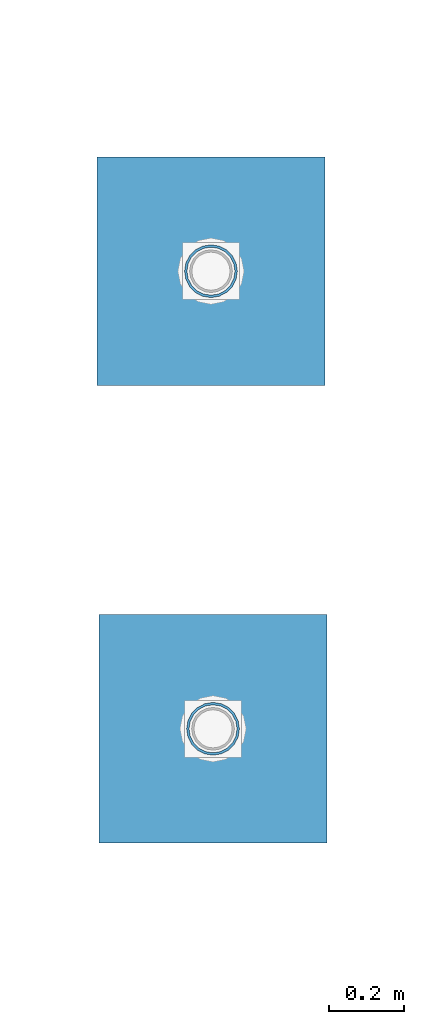
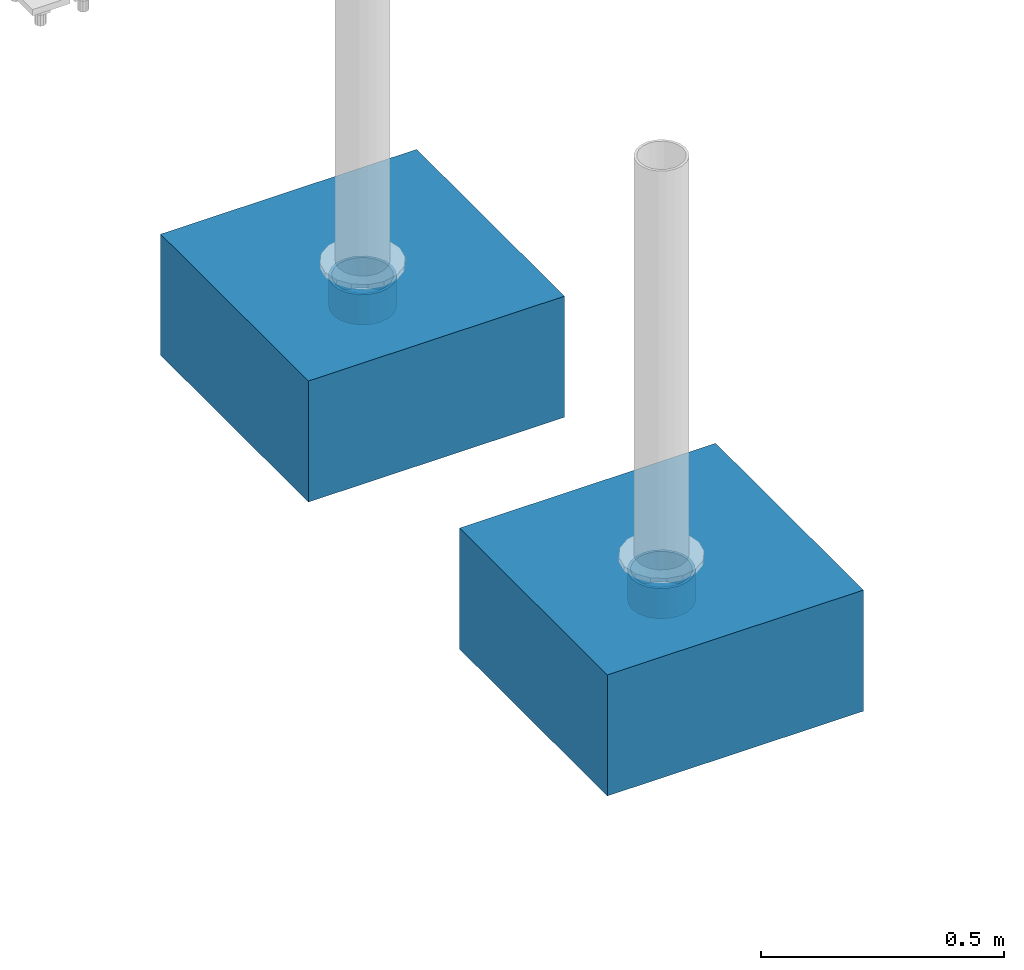
# One storey, part 1608 of 3843: 4 columns, 4 elements without a shape of their own.
"""IFC2X3 building model written with IfcOpenShell, lengths in millimetres."""

from ifc_helpers import new_model, si_unit, frame, origin_with_axes, place, context, subcontext, project, spatial, faceted_brep, material, type_object, element, aggregate, save


model = new_model("IFC2X3")

# Units and contexts
model_context = context("Model", 3, precision=1e-05, world=origin_with_axes())
body_context = subcontext(model_context, "Body", "Model", "MODEL_VIEW")
ifc_project = project(units=[si_unit("LENGTHUNIT", "METRE", prefix="MILLI"), si_unit("AREAUNIT", "SQUARE_METRE"), si_unit("VOLUMEUNIT", "CUBIC_METRE"), si_unit("MASSUNIT", "GRAM", prefix="KILO"), si_unit("TIMEUNIT", "SECOND"), si_unit("PLANEANGLEUNIT", "RADIAN"), si_unit("SOLIDANGLEUNIT", "STERADIAN"), si_unit("THERMODYNAMICTEMPERATUREUNIT", "DEGREE_CELSIUS"), si_unit("LUMINOUSINTENSITYUNIT", "LUMEN")], contexts=[model_context])

# Site, building, storey
site_placement = place(None, origin_with_axes())
site = spatial("IfcSite", under=ifc_project, at=site_placement, CompositionType="ELEMENT")
building_placement = place(site_placement, origin_with_axes())
building = spatial("IfcBuilding", under=site, at=building_placement, Name="Undefined", CompositionType="ELEMENT")
storey_placement = place(building_placement, origin_with_axes())
storey = spatial("IfcBuildingStorey", under=building, at=storey_placement, Name="Undefined", CompositionType="ELEMENT", Elevation=0.0)

# Assembly, column
assembly_1_placement = place(storey_placement, origin_with_axes())
assembly_1 = element("IfcElementAssembly", 1, at=assembly_1_placement, inside=storey, Name="PLATE", AssemblyPlace="NOTDEFINED", PredefinedType="RIGID_FRAME")
ifc_material_1 = material()
column_type_1 = type_object("IfcColumnType", Name="PIPE5SCH40", PredefinedType="NOTDEFINED")
column_1_placement = place(assembly_1_placement, frame((85108.6215818226, 7577.33566308022, 30378.4), z_axis=(-1.0, 0.0, 0.0), x_axis=(0.0, 0.0, 1.0)))
column_1 = element("IfcColumn", 2, at=column_1_placement, type_object=column_type_1, material=ifc_material_1, Name="PIPE_SLEEVE", ObjectType="PIPE5SCH40", context=body_context, shape_type="Brep", body=[
    faceted_brep([(0.0, -64.0587999999998, 0.0), (0.0, -60.9235391660477, 19.7952578392724), (76.2000000000007, -60.9235391660477, 19.7952578392724), (76.2000000000007, -64.0587999999998, 0.0), (0.0, -51.8246578392655, 37.6528179195593), (76.2000000000007, -51.8246578392655, 37.6528179195593), (0.0, -37.6528179195529, 51.8246578392718), (76.2000000000007, -37.6528179195529, 51.8246578392718), (0.0, -19.795257839266, 60.9235391660477), (76.2000000000007, -19.795257839266, 60.9235391660477), (0.0, 0.0, 64.0587999999989), (76.2000000000007, 0.0, 64.0587999999989), (0.0, 19.795257839266, 60.9235391660477), (76.2000000000007, 19.795257839266, 60.9235391660477), (0.0, 37.6528179195529, 51.8246578392718), (76.2000000000007, 37.6528179195529, 51.8246578392718), (0.0, 51.8246578392655, 37.6528179195593), (76.2000000000007, 51.8246578392655, 37.6528179195593), (0.0, 60.9235391660477, 19.7952578392724), (76.2000000000007, 60.9235391660477, 19.7952578392724), (0.0, 64.0587999999998, 0.0), (76.2000000000007, 64.0587999999998, 0.0), (0.0, 60.9235391660477, -19.7952578392724), (76.2000000000007, 60.9235391660477, -19.7952578392724), (0.0, 51.8246578392655, -37.6528179195593), (76.2000000000007, 51.8246578392655, -37.6528179195593), (0.0, 37.6528179195529, -51.8246578392718), (76.2000000000007, 37.6528179195529, -51.8246578392718), (0.0, 19.795257839266, -60.9235391660477), (76.2000000000007, 19.795257839266, -60.9235391660477), (0.0, 0.0, -64.0587999999989), (76.2000000000007, 0.0, -64.0587999999989), (0.0, -19.795257839266, -60.9235391660477), (76.2000000000007, -19.795257839266, -60.9235391660477), (0.0, -37.6528179195529, -51.8246578392718), (76.2000000000007, -37.6528179195529, -51.8246578392718), (0.0, -51.8246578392655, -37.6528179195593), (76.2000000000007, -51.8246578392655, -37.6528179195593), (0.0, -60.9235391660477, -19.7952578392724), (76.2000000000007, -60.9235391660477, -19.7952578392724), (0.0, -70.6120000000001, 0.0), (0.0, -67.1560027286332, -21.8203080068051), (76.2000000000007, -67.1560027286332, -21.8203080068051), (76.2000000000007, -70.6120000000001, 0.0), (0.0, -57.1263080068038, -41.5046922348702), (76.2000000000007, -57.1263080068038, -41.5046922348702), (0.0, -41.5046922348765, -57.126308006802), (76.2000000000007, -41.5046922348765, -57.126308006802), (0.0, -21.8203080068042, -67.1560027286323), (76.2000000000007, -21.8203080068042, -67.1560027286323), (0.0, 0.0, -70.6119999999937), (76.2000000000007, 0.0, -70.6119999999937), (0.0, 21.8203080068042, -67.1560027286323), (76.2000000000007, 21.8203080068042, -67.1560027286323), (0.0, 41.5046922348765, -57.126308006802), (76.2000000000007, 41.5046922348765, -57.126308006802), (0.0, 57.1263080068038, -41.5046922348702), (76.2000000000007, 57.1263080068038, -41.5046922348702), (0.0, 67.1560027286332, -21.8203080068051), (76.2000000000007, 67.1560027286332, -21.8203080068051), (0.0, 70.6120000000001, 0.0), (76.2000000000007, 70.6120000000001, 0.0), (0.0, 67.1560027286332, 21.8203080068051), (76.2000000000007, 67.1560027286332, 21.8203080068051), (0.0, 57.1263080068038, 41.5046922348702), (76.2000000000007, 57.1263080068038, 41.5046922348702), (0.0, 41.5046922348765, 57.126308006802), (76.2000000000007, 41.5046922348765, 57.126308006802), (0.0, 21.8203080068042, 67.1560027286323), (76.2000000000007, 21.8203080068042, 67.1560027286323), (0.0, 0.0, 70.6119999999937), (76.2000000000007, 0.0, 70.6119999999937), (0.0, -21.8203080068042, 67.1560027286323), (76.2000000000007, -21.8203080068042, 67.1560027286323), (0.0, -41.5046922348765, 57.126308006802), (76.2000000000007, -41.5046922348765, 57.126308006802), (0.0, -57.1263080068038, 41.5046922348702), (76.2000000000007, -57.1263080068038, 41.5046922348702), (0.0, -67.1560027286332, 21.8203080068051), (76.2000000000007, -67.1560027286332, 21.8203080068051)], [[[0, 1, 2, 3]], [[1, 4, 5, 2]], [[4, 6, 7, 5]], [[6, 8, 9, 7]], [[8, 10, 11, 9]], [[10, 12, 13, 11]], [[12, 14, 15, 13]], [[14, 16, 17, 15]], [[16, 18, 19, 17]], [[18, 20, 21, 19]], [[20, 22, 23, 21]], [[22, 24, 25, 23]], [[24, 26, 27, 25]], [[26, 28, 29, 27]], [[28, 30, 31, 29]], [[30, 32, 33, 31]], [[32, 34, 35, 33]], [[34, 36, 37, 35]], [[36, 38, 39, 37]], [[38, 0, 3, 39]], [[40, 41, 42, 43]], [[41, 44, 45, 42]], [[44, 46, 47, 45]], [[46, 48, 49, 47]], [[48, 50, 51, 49]], [[50, 52, 53, 51]], [[52, 54, 55, 53]], [[54, 56, 57, 55]], [[56, 58, 59, 57]], [[58, 60, 61, 59]], [[60, 62, 63, 61]], [[62, 64, 65, 63]], [[64, 66, 67, 65]], [[66, 68, 69, 67]], [[68, 70, 71, 69]], [[70, 72, 73, 71]], [[72, 74, 75, 73]], [[74, 76, 77, 75]], [[76, 78, 79, 77]], [[78, 40, 43, 79]], [[45, 47, 49, 51, 53, 55, 57, 59, 61, 63, 65, 67, 69, 71, 73, 75, 77, 79, 43, 42], [5, 7, 9, 11, 13, 15, 17, 19, 21, 23, 25, 27, 29, 31, 33, 35, 37, 39, 3, 2]], [[78, 76, 74, 72, 70, 68, 66, 64, 62, 60, 58, 56, 54, 52, 50, 48, 46, 44, 41, 40], [38, 36, 34, 32, 30, 28, 26, 24, 22, 20, 18, 16, 14, 12, 10, 8, 6, 4, 1, 0]]]),
])
aggregate(assembly_1, [column_1])

assembly_2_placement = place(storey_placement, origin_with_axes())
assembly_2 = element("IfcElementAssembly", 3, at=assembly_2_placement, inside=storey, Name="PLATE", AssemblyPlace="NOTDEFINED", PredefinedType="RIGID_FRAME")
column_2_placement = place(assembly_2_placement, frame((85103.0444944203, 8800.22079491616, 30378.4), z_axis=(-1.0, 0.0, 0.0), x_axis=(0.0, 0.0, 1.0)))
column_2 = element("IfcColumn", 4, at=column_2_placement, type_object=column_type_1, material=ifc_material_1, Name="PIPE_SLEEVE", ObjectType="PIPE5SCH40", context=body_context, shape_type="Brep", body=[
    faceted_brep([(0.0, -64.0587999999998, 0.0), (0.0, -60.9235391660477, 19.7952578392724), (76.2000000000007, -60.9235391660477, 19.7952578392724), (76.2000000000007, -64.0587999999998, 0.0), (0.0, -51.8246578392655, 37.6528179195593), (76.2000000000007, -51.8246578392655, 37.6528179195593), (0.0, -37.6528179195529, 51.8246578392718), (76.2000000000007, -37.6528179195529, 51.8246578392718), (0.0, -19.795257839266, 60.9235391660477), (76.2000000000007, -19.795257839266, 60.9235391660477), (0.0, 0.0, 64.0587999999989), (76.2000000000007, 0.0, 64.0587999999989), (0.0, 19.795257839266, 60.9235391660477), (76.2000000000007, 19.795257839266, 60.9235391660477), (0.0, 37.6528179195529, 51.8246578392718), (76.2000000000007, 37.6528179195529, 51.8246578392718), (0.0, 51.8246578392655, 37.6528179195593), (76.2000000000007, 51.8246578392655, 37.6528179195593), (0.0, 60.9235391660477, 19.7952578392724), (76.2000000000007, 60.9235391660477, 19.7952578392724), (0.0, 64.0587999999998, 0.0), (76.2000000000007, 64.0587999999998, 0.0), (0.0, 60.9235391660477, -19.7952578392724), (76.2000000000007, 60.9235391660477, -19.7952578392724), (0.0, 51.8246578392655, -37.6528179195593), (76.2000000000007, 51.8246578392655, -37.6528179195593), (0.0, 37.6528179195529, -51.8246578392718), (76.2000000000007, 37.6528179195529, -51.8246578392718), (0.0, 19.795257839266, -60.9235391660477), (76.2000000000007, 19.795257839266, -60.9235391660477), (0.0, 0.0, -64.0587999999989), (76.2000000000007, 0.0, -64.0587999999989), (0.0, -19.795257839266, -60.9235391660477), (76.2000000000007, -19.795257839266, -60.9235391660477), (0.0, -37.6528179195529, -51.8246578392718), (76.2000000000007, -37.6528179195529, -51.8246578392718), (0.0, -51.8246578392655, -37.6528179195593), (76.2000000000007, -51.8246578392655, -37.6528179195593), (0.0, -60.9235391660477, -19.7952578392724), (76.2000000000007, -60.9235391660477, -19.7952578392724), (0.0, -70.6120000000001, 0.0), (0.0, -67.1560027286332, -21.8203080068051), (76.2000000000007, -67.1560027286332, -21.8203080068051), (76.2000000000007, -70.6120000000001, 0.0), (0.0, -57.1263080068038, -41.5046922348702), (76.2000000000007, -57.1263080068038, -41.5046922348702), (0.0, -41.5046922348765, -57.126308006802), (76.2000000000007, -41.5046922348765, -57.126308006802), (0.0, -21.8203080068042, -67.1560027286323), (76.2000000000007, -21.8203080068042, -67.1560027286323), (0.0, 0.0, -70.6119999999937), (76.2000000000007, 0.0, -70.6119999999937), (0.0, 21.8203080068042, -67.1560027286323), (76.2000000000007, 21.8203080068042, -67.1560027286323), (0.0, 41.5046922348765, -57.126308006802), (76.2000000000007, 41.5046922348765, -57.126308006802), (0.0, 57.1263080068038, -41.5046922348702), (76.2000000000007, 57.1263080068038, -41.5046922348702), (0.0, 67.1560027286332, -21.8203080068051), (76.2000000000007, 67.1560027286332, -21.8203080068051), (0.0, 70.6120000000001, 0.0), (76.2000000000007, 70.6120000000001, 0.0), (0.0, 67.1560027286332, 21.8203080068051), (76.2000000000007, 67.1560027286332, 21.8203080068051), (0.0, 57.1263080068038, 41.5046922348702), (76.2000000000007, 57.1263080068038, 41.5046922348702), (0.0, 41.5046922348765, 57.126308006802), (76.2000000000007, 41.5046922348765, 57.126308006802), (0.0, 21.8203080068042, 67.1560027286323), (76.2000000000007, 21.8203080068042, 67.1560027286323), (0.0, 0.0, 70.6119999999937), (76.2000000000007, 0.0, 70.6119999999937), (0.0, -21.8203080068042, 67.1560027286323), (76.2000000000007, -21.8203080068042, 67.1560027286323), (0.0, -41.5046922348765, 57.126308006802), (76.2000000000007, -41.5046922348765, 57.126308006802), (0.0, -57.1263080068038, 41.5046922348702), (76.2000000000007, -57.1263080068038, 41.5046922348702), (0.0, -67.1560027286332, 21.8203080068051), (76.2000000000007, -67.1560027286332, 21.8203080068051)], [[[0, 1, 2, 3]], [[1, 4, 5, 2]], [[4, 6, 7, 5]], [[6, 8, 9, 7]], [[8, 10, 11, 9]], [[10, 12, 13, 11]], [[12, 14, 15, 13]], [[14, 16, 17, 15]], [[16, 18, 19, 17]], [[18, 20, 21, 19]], [[20, 22, 23, 21]], [[22, 24, 25, 23]], [[24, 26, 27, 25]], [[26, 28, 29, 27]], [[28, 30, 31, 29]], [[30, 32, 33, 31]], [[32, 34, 35, 33]], [[34, 36, 37, 35]], [[36, 38, 39, 37]], [[38, 0, 3, 39]], [[40, 41, 42, 43]], [[41, 44, 45, 42]], [[44, 46, 47, 45]], [[46, 48, 49, 47]], [[48, 50, 51, 49]], [[50, 52, 53, 51]], [[52, 54, 55, 53]], [[54, 56, 57, 55]], [[56, 58, 59, 57]], [[58, 60, 61, 59]], [[60, 62, 63, 61]], [[62, 64, 65, 63]], [[64, 66, 67, 65]], [[66, 68, 69, 67]], [[68, 70, 71, 69]], [[70, 72, 73, 71]], [[72, 74, 75, 73]], [[74, 76, 77, 75]], [[76, 78, 79, 77]], [[78, 40, 43, 79]], [[45, 47, 49, 51, 53, 55, 57, 59, 61, 63, 65, 67, 69, 71, 73, 75, 77, 79, 43, 42], [5, 7, 9, 11, 13, 15, 17, 19, 21, 23, 25, 27, 29, 31, 33, 35, 37, 39, 3, 2]], [[78, 76, 74, 72, 70, 68, 66, 64, 62, 60, 58, 56, 54, 52, 50, 48, 46, 44, 41, 40], [38, 36, 34, 32, 30, 28, 26, 24, 22, 20, 18, 16, 14, 12, 10, 8, 6, 4, 1, 0]]]),
])
aggregate(assembly_2, [column_2])

assembly_3_placement = place(storey_placement, origin_with_axes())
assembly_3 = element("IfcElementAssembly", 5, at=assembly_3_placement, inside=storey, Name="CONC_COL.", AssemblyPlace="NOTDEFINED", PredefinedType="REINFORCEMENT_UNIT")
ifc_material_2 = material(Name="CONCRETE/3000")
column_type_2 = type_object("IfcColumnType", PredefinedType="NOTDEFINED")
column_3_placement = place(assembly_3_placement, frame((85108.6215818226, 7577.33566308022, 30175.2), z_axis=(-1.0, 0.0, 0.0), x_axis=(0.0, 0.0, 1.0)))
column_3 = element("IfcColumn", 6, at=column_3_placement, type_object=column_type_2, material=ifc_material_2, Name="CONC_COL.", context=body_context, shape_type="Brep", body=[
    faceted_brep([(0.0, 304.8, -304.800000000003), (0.0, 304.8, 304.800000000003), (304.799999999999, 304.8, 304.800000000003), (304.799999999999, 304.8, -304.800000000003), (0.0, -304.8, 304.800000000003), (304.799999999999, -304.8, 304.800000000003), (0.0, -304.8, -304.800000000003), (304.799999999999, -304.8, -304.800000000003)], [[[0, 1, 2, 3]], [[1, 4, 5, 2]], [[4, 6, 7, 5]], [[6, 0, 3, 7]], [[5, 7, 3, 2]], [[6, 4, 1, 0]]]),
])
aggregate(assembly_3, [column_3])

assembly_4_placement = place(storey_placement, origin_with_axes())
assembly_4 = element("IfcElementAssembly", 7, at=assembly_4_placement, inside=storey, Name="CONC_COL.", AssemblyPlace="NOTDEFINED", PredefinedType="REINFORCEMENT_UNIT")
column_4_placement = place(assembly_4_placement, frame((85103.0444944203, 8800.22079491616, 30175.2), z_axis=(-1.0, 0.0, 0.0), x_axis=(0.0, 0.0, 1.0)))
column_4 = element("IfcColumn", 8, at=column_4_placement, type_object=column_type_2, material=ifc_material_2, Name="CONC_COL.", context=body_context, shape_type="Brep", body=[
    faceted_brep([(0.0, 304.8, -304.800000000003), (0.0, 304.8, 304.800000000003), (304.799999999999, 304.8, 304.800000000003), (304.799999999999, 304.8, -304.800000000003), (0.0, -304.8, 304.800000000003), (304.799999999999, -304.8, 304.800000000003), (0.0, -304.8, -304.800000000003), (304.799999999999, -304.8, -304.800000000003)], [[[0, 1, 2, 3]], [[1, 4, 5, 2]], [[4, 6, 7, 5]], [[6, 0, 3, 7]], [[5, 7, 3, 2]], [[6, 4, 1, 0]]]),
])
aggregate(assembly_4, [column_4])

save(model, "model.ifc")
